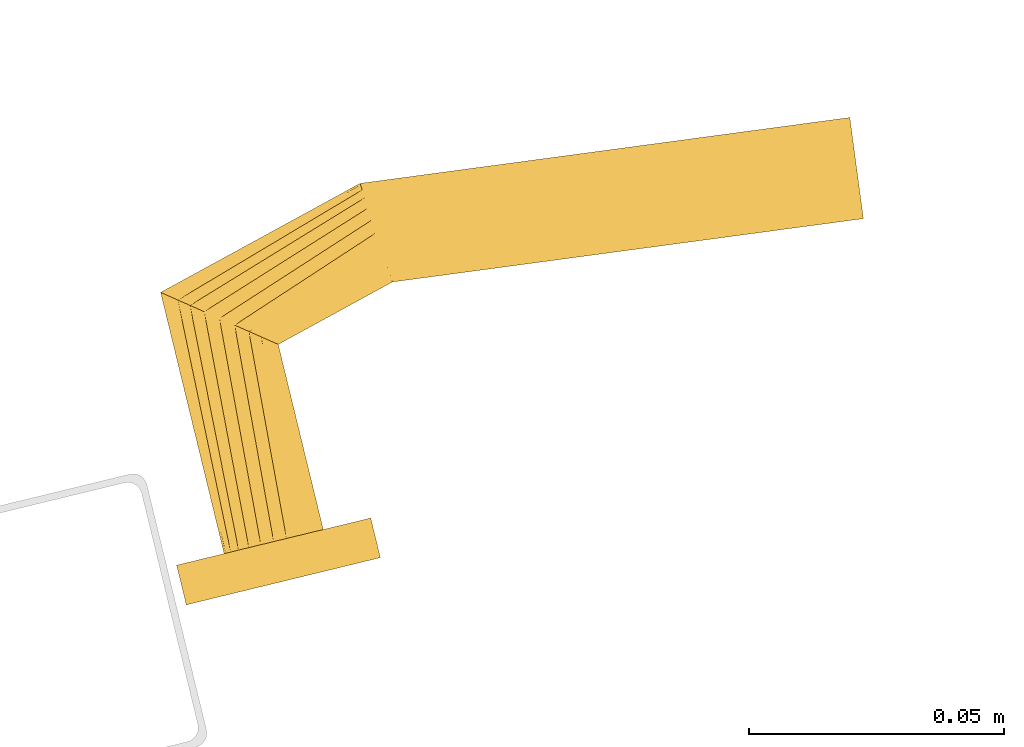
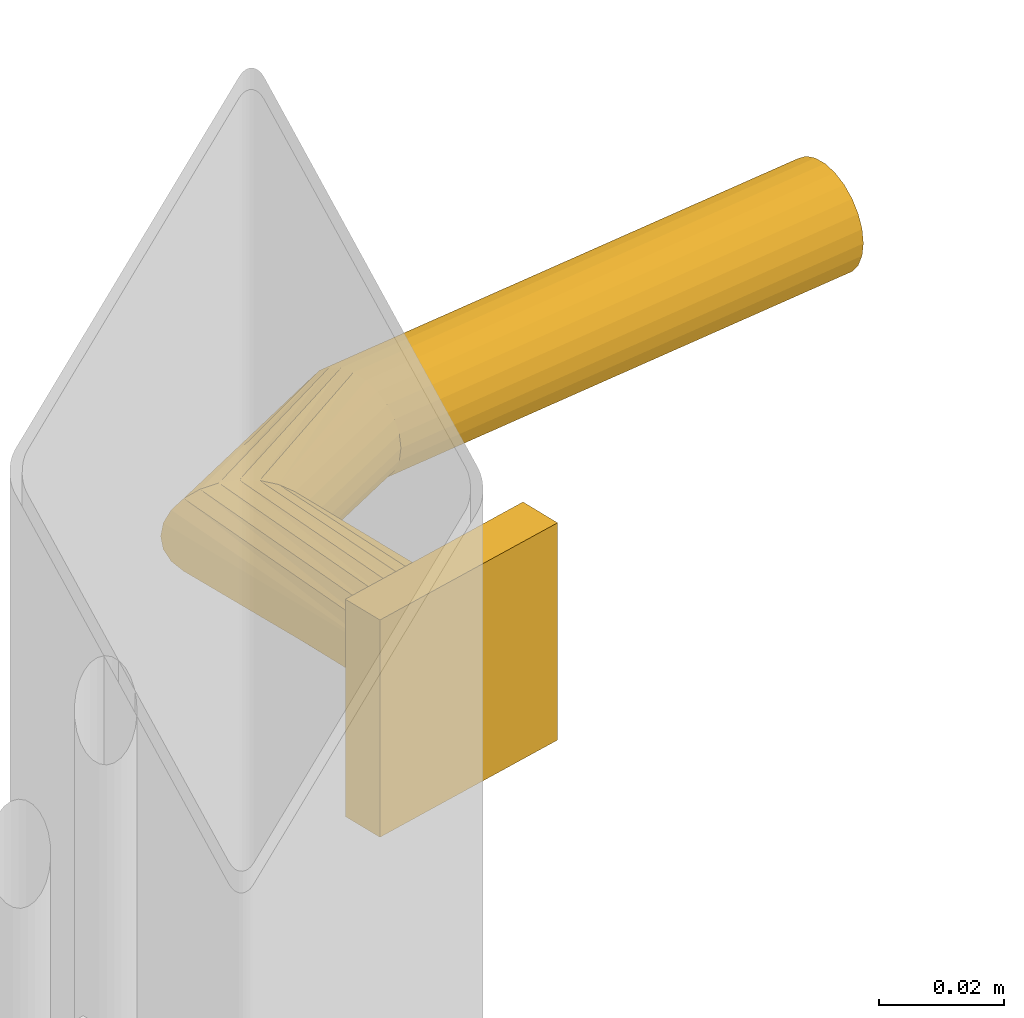
# One storey, part 10 of 10: 1 door.
"""IFC2X3 building model written with IfcOpenShell, lengths in millimetres."""

from ifc_helpers import new_model, entity, si_unit, converted_unit, derived_unit, direction, frame, origin, place, context, subcontext, project, spatial, faceted_brep, source, transform, mapped, material, type_object, type_shapes, element, save


model = new_model("IFC2X3")

# Units and contexts
model_context = context("Model", 3, precision=0.01, world=origin(), true_north=direction((6.12303176911189e-17, 1.0)))
body_context = subcontext(model_context, "Body", "Model", "MODEL_VIEW")
ifc_project = project(units=[si_unit("LENGTHUNIT", "METRE", prefix="MILLI"), si_unit("AREAUNIT", "SQUARE_METRE"), si_unit("VOLUMEUNIT", "CUBIC_METRE"), converted_unit("PLANEANGLEUNIT", "DEGREE", entity("IfcRatioMeasure", 0.0174532925199433), si_unit("PLANEANGLEUNIT", "RADIAN"), dimensions=[0, 0, 0, 0, 0, 0, 0]), si_unit("MASSUNIT", "GRAM", prefix="KILO"), derived_unit("MASSDENSITYUNIT", [(si_unit("MASSUNIT", "GRAM", prefix="KILO"), 1), (si_unit("LENGTHUNIT", "METRE"), -3)]), derived_unit("MOMENTOFINERTIAUNIT", [(si_unit("LENGTHUNIT", "METRE"), 4)]), si_unit("TIMEUNIT", "SECOND"), si_unit("FREQUENCYUNIT", "HERTZ"), si_unit("THERMODYNAMICTEMPERATUREUNIT", "DEGREE_CELSIUS"), derived_unit("THERMALTRANSMITTANCEUNIT", [(si_unit("MASSUNIT", "GRAM", prefix="KILO"), 1), (si_unit("THERMODYNAMICTEMPERATUREUNIT", "KELVIN"), -1), (si_unit("TIMEUNIT", "SECOND"), -3)]), derived_unit("VOLUMETRICFLOWRATEUNIT", [(si_unit("LENGTHUNIT", "METRE"), 3), (si_unit("TIMEUNIT", "SECOND"), -1)]), derived_unit("MASSFLOWRATEUNIT", [(si_unit("MASSUNIT", "GRAM", prefix="KILO"), 1), (si_unit("TIMEUNIT", "SECOND"), -1)]), derived_unit("ROTATIONALFREQUENCYUNIT", [(si_unit("TIMEUNIT", "SECOND"), -1)]), si_unit("ELECTRICCURRENTUNIT", "AMPERE"), si_unit("ELECTRICVOLTAGEUNIT", "VOLT"), si_unit("POWERUNIT", "WATT"), si_unit("FORCEUNIT", "NEWTON", prefix="KILO"), si_unit("ILLUMINANCEUNIT", "LUX"), si_unit("LUMINOUSFLUXUNIT", "LUMEN"), si_unit("LUMINOUSINTENSITYUNIT", "CANDELA"), derived_unit("USERDEFINED", [(si_unit("MASSUNIT", "GRAM", prefix="KILO"), -1), (si_unit("LENGTHUNIT", "METRE"), -2), (si_unit("TIMEUNIT", "SECOND"), 3), (si_unit("LUMINOUSFLUXUNIT", "LUMEN"), 1)]), derived_unit("LINEARVELOCITYUNIT", [(si_unit("LENGTHUNIT", "METRE"), 1), (si_unit("TIMEUNIT", "SECOND"), -1)]), si_unit("PRESSUREUNIT", "PASCAL"), derived_unit("USERDEFINED", [(si_unit("LENGTHUNIT", "METRE"), -2), (si_unit("MASSUNIT", "GRAM", prefix="KILO"), 1), (si_unit("TIMEUNIT", "SECOND"), -2)]), derived_unit("LINEARFORCEUNIT", [(si_unit("MASSUNIT", "GRAM", prefix="KILO"), 1), (si_unit("LENGTHUNIT", "METRE"), 1), (si_unit("TIMEUNIT", "SECOND"), -2), (si_unit("LENGTHUNIT", "METRE"), -1)]), derived_unit("PLANARFORCEUNIT", [(si_unit("MASSUNIT", "GRAM", prefix="KILO"), 1), (si_unit("LENGTHUNIT", "METRE"), 1), (si_unit("TIMEUNIT", "SECOND"), -2), (si_unit("LENGTHUNIT", "METRE"), -2)])], contexts=[model_context])

# Site, building, storey
site_placement = place(None, frame((19171.746869958, -72498.5768491146, 0.0), z_axis=(0.0, 0.0, 1.0), x_axis=(0.971695960795463, 0.236234967296933, 0.0)))
site = spatial("IfcSite", under=ifc_project, at=site_placement, CompositionType="ELEMENT")
building_placement = place(site_placement, origin())
building = spatial("IfcBuilding", under=site, at=building_placement, CompositionType="ELEMENT")
storey_placement = place(building_placement, origin())
storey = spatial("IfcBuildingStorey", under=building, at=storey_placement, CompositionType="ELEMENT", Elevation=0.0)

# Door
ifc_material = material(Name="Metal - Aluminium")
door_style = type_object("IfcDoorStyle", Name="Handle (6):Handle (6)", ConstructionType="NOTDEFINED", OperationType="NOTDEFINED", ParameterTakesPrecedence=False, Sizeable=False, material=ifc_material)
shared_shape = source(origin(), body_context, "Body", "Brep", [
    faceted_brep([(222.411809548956, 8.0, -9.6592582628912), (225.0, 8.0, -10.0), (227.588190451006, 8.0, -9.65925826289127), (230.0, 8.0, -8.660254037845), (232.071067811846, 8.0, -7.07106781186612), (233.660254037825, 8.0, -5.0), (234.659258262872, 8.0, -2.58819045102584), (235.0, 8.0, 0.0), (234.659258262872, 8.0, 2.58819045102469), (233.660254037826, 8.0, 5.0), (232.071067811847, 8.0, 7.07106781186503), (230.0, 8.0, 8.66025403784397), (227.588190451006, 8.0, 9.65925826289031), (225.0, 8.0, 10.0), (222.411809548956, 8.0, 9.65925826289036), (220.0, 8.0, 8.66025403784408), (217.928932188116, 8.0, 7.07106781186518), (216.339745962137, 8.0, 5.0), (215.34074173709, 8.0, 2.5881904510249), (215.0, 8.0, 0.0), (215.34074173709, 8.0, -2.58819045102556), (216.339745962137, 8.0, -5.0), (217.928932188115, 8.0, -7.0710678118659), (220.0, 8.0, -8.66025403784486), (215.0, 60.6732698797976, 0.0), (215.34074173709, 60.4118095489827, -2.58819045102548), (216.339745962137, 59.6452466459997, -5.0), (217.928932188115, 58.4258211658816, -7.07106781186588), (220.0, 56.8366349399025, -8.66025403784485), (222.411809548956, 54.9859883831087, -9.65925826289119), (225.0, 53.0, -10.0), (227.588190451006, 51.0140116169062, -9.65925826289127), (230.0, 49.1633650601124, -8.66025403784503), (232.071067811846, 47.5741788341333, -7.07106781186614), (234.659258262872, 45.588190451032, -2.58819045102591), (235.0, 45.3267301202172, 0.0), (233.660254037825, 46.3547533540152, -5.0), (233.660254037826, 46.3547533540151, 5.0), (232.071067811847, 47.5741788341332, 7.07106781186502), (234.659258262872, 45.588190451032, 2.58819045102469), (230.0, 49.1633650601123, 8.66025403784397), (227.588190451006, 51.0140116169061, 9.65925826289031), (225.0, 53.0, 10.0), (220.0, 56.8366349399024, 8.66025403784408), (222.411809548956, 54.9859883831086, 9.65925826289036), (217.928932188116, 58.4258211658815, 7.07106781186518), (216.339745962137, 59.6452466459996, 5.0), (215.34074173709, 60.4118095489827, 2.5881904510249), (258.00959194588, 72.1976553084904, 0.0), (258.036776729678, 71.8521776452549, -2.58819045102562), (258.116478482983, 70.8392883873687, -5.0), (258.243265663019, 69.2280142638783, -7.07106781186598), (258.408497932993, 67.1281609435431, -8.66025403784494), (258.600914986765, 64.6828299599722, -9.65925826289129), (258.807403920106, 62.0586665785956, -10.0), (259.206309907219, 56.989172213648, -8.66025403784514), (259.371542177193, 54.8893188933127, -7.07106781186625), (259.013892853447, 59.4345031972189, -9.6592582628914), (259.578031110534, 52.265155511936, -2.58819045102599), (259.605215894332, 51.9196778487003, 0.0), (259.498329357229, 53.2780447698222, -5.0), (259.498329357229, 53.2780447698221, 5.0), (259.371542177193, 54.8893188933125, 7.07106781186495), (259.578031110534, 52.2651555119359, 2.58819045102461), (259.013892853447, 59.4345031972187, 9.65925826289021), (258.807403920106, 62.0586665785953, 10.0), (259.206309907219, 56.9891722136478, 8.66025403784389), (258.600914986766, 64.682829959972, 9.65925826289023), (258.408497932993, 67.1281609435429, 8.66025403784394), (258.243265663019, 69.2280142638781, 7.07106781186503), (258.116478482983, 70.8392883873686, 5.0), (258.036776729678, 71.8521776452548, 2.58819045102475), (353.531991524642, 54.7024670162027, -9.65925826289162), (353.784161863449, 57.1010573148473, -8.66025403784528), (354.000705442536, 59.160773499107, -7.07106781186634), (354.166865174843, 60.7412493148666, -5.0), (354.271317549205, 61.7347779471417, -2.588190451026), (354.306944308925, 62.0736520615265, 0.0), (354.271317549205, 61.7347779471416, 2.58819045102445), (354.166865174843, 60.7412493148665, 5.0), (354.000705442536, 59.1607734991069, 7.07106781186471), (353.784161863449, 57.1010573148471, 8.66025403784364), (353.531991524642, 54.7024670162025, 9.65925826288992), (353.261379417973, 52.1284625681678, 10.0), (352.990767311304, 49.5544581201331, 9.6592582628899), (352.738596972497, 47.1558678214885, 8.66025403784359), (352.522053393411, 45.0961516372287, 7.07106781186465), (352.355893661104, 43.5156758214692, 5.0), (352.251441286742, 42.5221471891941, 2.58819045102432), (352.215814527021, 42.1832730748093, 0.0), (352.251441286742, 42.5221471891941, -2.58819045102622), (352.355893661104, 43.5156758214693, -5.0), (352.522053393411, 45.0961516372289, -7.07106781186651), (352.738596972497, 47.1558678214887, -8.66025403784542), (352.990767311304, 49.5544581201333, -9.65925826289169), (353.261379417973, 52.128462568168, -10.0)], [[[0, 1, 2, 3, 4, 5, 6, 7, 8, 9, 10, 11, 12, 13, 14, 15, 16, 17, 18, 19, 20, 21, 22, 23]], [[19, 24, 25, 20]], [[26, 20, 25]], [[21, 27, 28]], [[26, 27, 20]], [[22, 28, 29]], [[27, 21, 20]], [[0, 30, 31]], [[30, 0, 23]], [[22, 29, 23]], [[22, 21, 28]], [[29, 30, 23]], [[32, 33, 2]], [[31, 32, 1]], [[34, 35, 7, 6]], [[36, 34, 6, 5]], [[33, 36, 5, 4]], [[33, 3, 2]], [[2, 1, 32]], [[4, 3, 33]], [[31, 1, 0]], [[37, 38, 10, 9]], [[39, 37, 9, 8]], [[13, 40, 41]], [[12, 40, 13]], [[38, 40, 12]], [[35, 39, 8, 7]], [[11, 10, 38]], [[38, 12, 11]], [[41, 42, 14]], [[43, 16, 44]], [[45, 17, 43]], [[18, 46, 47]], [[45, 46, 18]], [[19, 18, 47, 24]], [[15, 14, 42]], [[13, 41, 14]], [[18, 17, 45]], [[16, 43, 17]], [[16, 15, 44]], [[42, 44, 15]], [[25, 24, 48, 49]], [[50, 27, 49]], [[29, 51, 52]], [[50, 51, 28]], [[30, 29, 52]], [[49, 26, 25]], [[31, 53, 54]], [[29, 28, 51]], [[27, 50, 28]], [[27, 26, 49]], [[52, 53, 30]], [[55, 56, 33, 32]], [[57, 55, 32]], [[58, 59, 35, 34]], [[60, 58, 34, 36]], [[56, 60, 36, 33]], [[30, 53, 31]], [[31, 54, 32]], [[54, 57, 32]], [[61, 62, 38, 37]], [[63, 61, 37, 39]], [[64, 65, 40]], [[66, 64, 40]], [[62, 66, 40, 38]], [[63, 39, 35, 59]], [[65, 41, 40]], [[65, 67, 41]], [[68, 42, 67]], [[69, 44, 68]], [[45, 70, 71]], [[69, 70, 43]], [[47, 71, 48, 24]], [[69, 43, 44]], [[44, 42, 68]], [[45, 71, 46]], [[47, 46, 71]], [[43, 70, 45]], [[67, 42, 41]], [[72, 73, 74, 75, 76, 77, 78, 79, 80, 81, 82, 83, 84, 85, 86, 87, 88, 89, 90, 91, 92, 93, 94, 95]], [[76, 49, 48, 77]], [[75, 50, 49, 76]], [[52, 51, 74, 73]], [[75, 74, 51, 50]], [[53, 52, 73, 72]], [[54, 53, 72, 95]], [[55, 57, 94, 93]], [[92, 56, 55, 93]], [[90, 89, 59, 58]], [[60, 56, 92, 91]], [[58, 60, 91, 90]], [[54, 95, 94, 57]], [[88, 63, 59, 89]], [[87, 61, 63, 88]], [[62, 86, 85, 66]], [[87, 86, 62, 61]], [[66, 85, 84, 64]], [[83, 65, 64, 84]], [[81, 68, 67, 82]], [[80, 69, 68, 81]], [[70, 79, 78, 71]], [[80, 79, 70, 69]], [[71, 78, 77, 48]], [[67, 65, 83, 82]]]),
    faceted_brep([(205.42832393375, 8.0, 19.0575533914141), (244.571676066241, 8.0, 19.0575533914141), (244.571676066241, 8.0, -23.2193468373923), (205.42832393375, 8.0, -23.2193468373923), (205.42832393375, 0.0, 19.0575533914141), (205.42832393375, 0.0, -23.2193468373923), (244.571676066241, 0.0, -23.2193468373923), (244.571676066241, 0.0, 19.0575533914141)], [[[0, 1, 2, 3]], [[4, 5, 6, 7]], [[1, 0, 4, 7]], [[2, 1, 7, 6]], [[3, 2, 6, 5]], [[0, 3, 5, 4]]]),
])
type_shapes(door_style, [shared_shape])
door_placement = place(storey_placement, frame((4224.0, 5600.0, 828.313130127307)))
element("IfcDoor", 1, at=door_placement, inside=storey, type_object=door_style, material=ifc_material, Name="Handle (6):Handle (6)", ObjectType="Handle (6):Handle (6)", OverallHeight=42.2769002288064, OverallWidth=204.30694430893, context=body_context, shape_type="MappedRepresentation", body=[
    mapped(shared_shape, transform((0.0, 0.0, 0.0), scale=1.0)),
])

save(model, "model.ifc")
